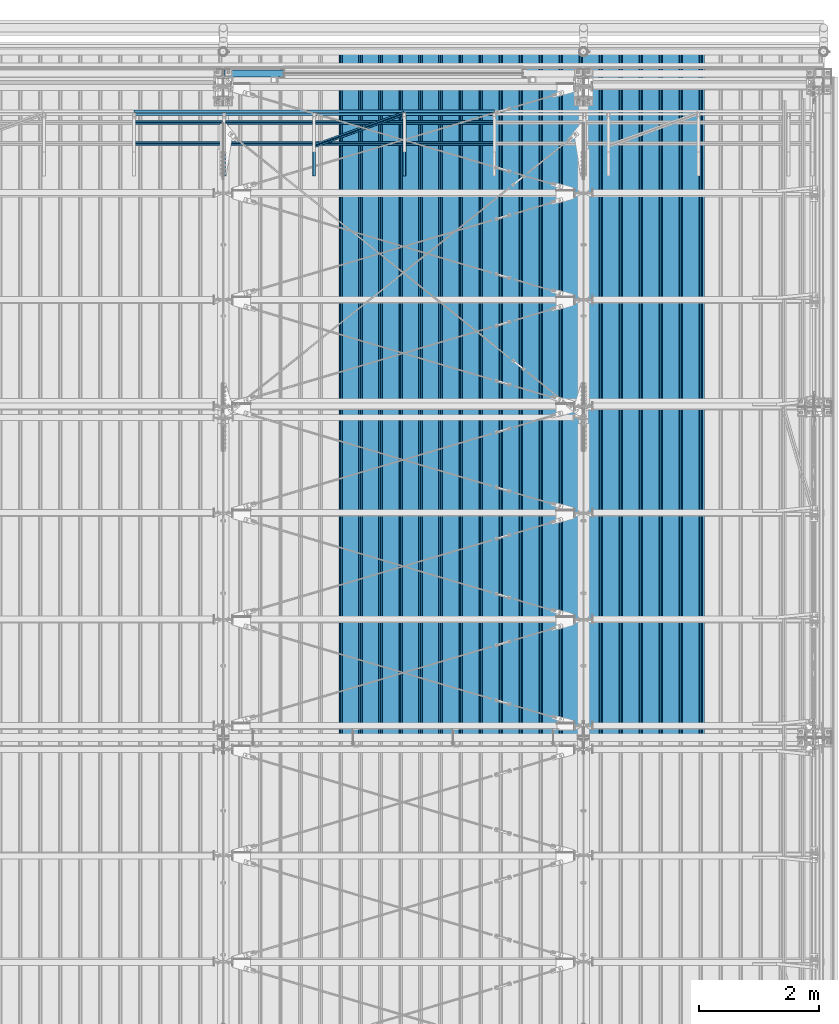
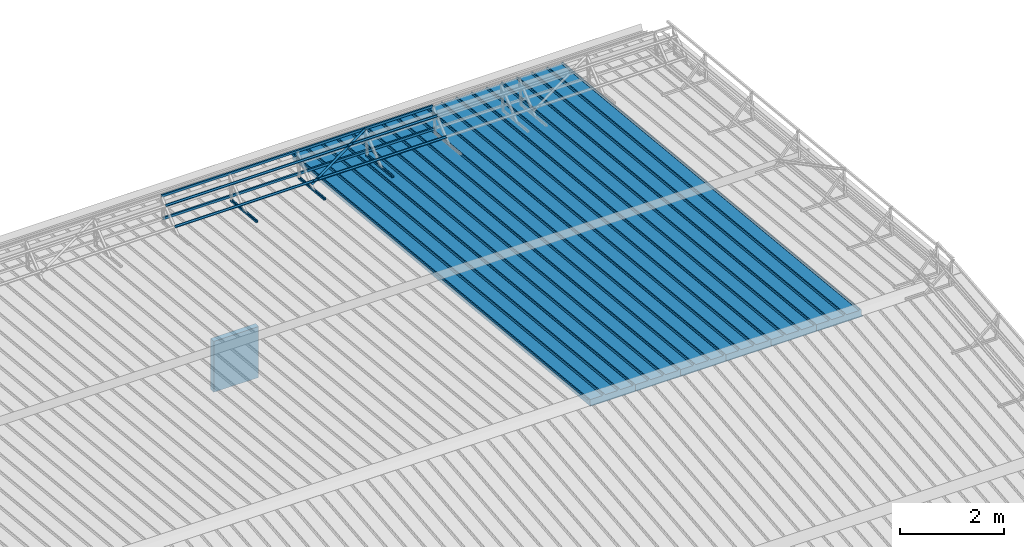
# One storey, part 77 of 709: 15 beams, 15 elements without a shape of their own.
"""IFC4 building model written with IfcOpenShell, lengths in millimetres."""

from ifc_helpers import new_model, si_unit, direction, frame, origin_with_axes, place, context, subcontext, project, spatial, line, indexed_curve, outline, extrude, material, element, aggregate, save


model = new_model("IFC4")

# Units and contexts
model_context = context("Model", 3, precision=0.2, world=origin_with_axes(), true_north=direction((0.0, 1.0)))
body_context = subcontext(model_context, "Body", "Model", "MODEL_VIEW")
ifc_project = project(units=[si_unit("LENGTHUNIT", "METRE", prefix="MILLI"), si_unit("AREAUNIT", "SQUARE_METRE"), si_unit("VOLUMEUNIT", "CUBIC_METRE"), si_unit("MASSUNIT", "GRAM", prefix="KILO"), si_unit("TIMEUNIT", "SECOND"), si_unit("PLANEANGLEUNIT", "RADIAN"), si_unit("SOLIDANGLEUNIT", "STERADIAN"), si_unit("THERMODYNAMICTEMPERATUREUNIT", "DEGREE_CELSIUS"), si_unit("LUMINOUSINTENSITYUNIT", "LUMEN")], contexts=[model_context])

# Site, building, storey
site_placement = place(None, origin_with_axes())
site = spatial("IfcSite", under=ifc_project, at=site_placement, CompositionType="ELEMENT")
building_placement = place(site_placement, origin_with_axes())
building = spatial("IfcBuilding", under=site, at=building_placement, Name="Undefined", CompositionType="ELEMENT")
storey_placement = place(building_placement, origin_with_axes())
storey = spatial("IfcBuildingStorey", under=building, at=storey_placement, Name="Undefined", CompositionType="ELEMENT", Elevation=0.0)

# Assembly, beam
assembly_1_placement = place(storey_placement, frame((47452.44, 11009.10459, 8419.96887), z_axis=(1.0, 0.0, 0.0), x_axis=(0.0, 0.9950371902, -0.099503719)))
assembly_1 = element("IfcElementAssembly", 1, at=assembly_1_placement, inside=storey)
ifc_material_1 = material(Name="Insulation", Category="Insulation")
beam_1_placement = place(assembly_1_placement, origin_with_axes())
beam_1 = element("IfcBeam", 2, at=beam_1_placement, material=ifc_material_1, ObjectType="P-99", context=body_context, shape_type="SolidModel", body=[
    extrude(outline(indexed_curve([(-509.8453, 89.5), (-490.1547, 89.5), (-471.67949, 57.5), (-471.67949, -88.5), (-436.67949, -88.5), (-436.67949, -91.5), (562.55841, -91.5), (562.55841, -89.5), (527.55841, -89.5), (527.55841, 57.5), (510.2379, 88.5), (489.7621, 88.5), (472.44159, 58.5), (196.71923, 58.5), (177.66667, 91.5), (155.66667, 91.5), (136.61411, 58.5), (-136.61411, 58.5), (-155.66667, 91.5), (-177.66667, 91.5), (-196.71923, 58.5), (-469.94744, 58.5), (-489.0, 91.5), (-511.0, 91.5), (-527.16581, 63.5), (-525.43376, 62.5)], segments=[line(1, 2, 3, 4, 5, 6, 7, 8, 9, 10, 11, 12, 13, 14, 15, 16, 17, 18, 19, 20, 21, 22, 23, 24, 25, 26, 1)])), frame((0.0, 0.0, 0.0), z_axis=(-1.0, 0.0, 0.0), x_axis=(0.0, 0.0, 1.0)), (0.0, 0.0, -1.0), 11459.0),
])
aggregate(assembly_1, [beam_1])

assembly_2_placement = place(storey_placement, frame((46452.44, 11009.10459, 8419.96887), z_axis=(1.0, 0.0, 0.0), x_axis=(0.0, 0.9950371902, -0.099503719)))
assembly_2 = element("IfcElementAssembly", 3, at=assembly_2_placement, inside=storey)
beam_2_placement = place(assembly_2_placement, origin_with_axes())
beam_2 = element("IfcBeam", 4, at=beam_2_placement, material=ifc_material_1, ObjectType="P-99", context=body_context, shape_type="SolidModel", body=[
    extrude(outline(indexed_curve([(-509.8453, 89.5), (-490.1547, 89.5), (-471.67949, 57.5), (-471.67949, -88.5), (-436.67949, -88.5), (-436.67949, -91.5), (562.55841, -91.5), (562.55841, -89.5), (527.55841, -89.5), (527.55841, 57.5), (510.2379, 88.5), (489.7621, 88.5), (472.44159, 58.5), (196.71923, 58.5), (177.66667, 91.5), (155.66667, 91.5), (136.61411, 58.5), (-136.61411, 58.5), (-155.66667, 91.5), (-177.66667, 91.5), (-196.71923, 58.5), (-469.94744, 58.5), (-489.0, 91.5), (-511.0, 91.5), (-527.16581, 63.5), (-525.43376, 62.5)], segments=[line(1, 2, 3, 4, 5, 6, 7, 8, 9, 10, 11, 12, 13, 14, 15, 16, 17, 18, 19, 20, 21, 22, 23, 24, 25, 26, 1)])), frame((0.0, 0.0, 0.0), z_axis=(-1.0, 0.0, 0.0), x_axis=(0.0, 0.0, 1.0)), (0.0, 0.0, -1.0), 11459.0),
])
aggregate(assembly_2, [beam_2])

assembly_3_placement = place(storey_placement, frame((45452.44, 11009.10459, 8419.96887), z_axis=(1.0, 0.0, 0.0), x_axis=(0.0, 0.9950371902, -0.099503719)))
assembly_3 = element("IfcElementAssembly", 5, at=assembly_3_placement, inside=storey)
beam_3_placement = place(assembly_3_placement, origin_with_axes())
beam_3 = element("IfcBeam", 6, at=beam_3_placement, material=ifc_material_1, ObjectType="P-99", context=body_context, shape_type="SolidModel", body=[
    extrude(outline(indexed_curve([(-509.8453, 89.5), (-490.1547, 89.5), (-471.67949, 57.5), (-471.67949, -88.5), (-436.67949, -88.5), (-436.67949, -91.5), (562.55841, -91.5), (562.55841, -89.5), (527.55841, -89.5), (527.55841, 57.5), (510.2379, 88.5), (489.7621, 88.5), (472.44159, 58.5), (196.71923, 58.5), (177.66667, 91.5), (155.66667, 91.5), (136.61411, 58.5), (-136.61411, 58.5), (-155.66667, 91.5), (-177.66667, 91.5), (-196.71923, 58.5), (-469.94744, 58.5), (-489.0, 91.5), (-511.0, 91.5), (-527.16581, 63.5), (-525.43376, 62.5)], segments=[line(1, 2, 3, 4, 5, 6, 7, 8, 9, 10, 11, 12, 13, 14, 15, 16, 17, 18, 19, 20, 21, 22, 23, 24, 25, 26, 1)])), frame((0.0, 0.0, 0.0), z_axis=(-1.0, 0.0, 0.0), x_axis=(0.0, 0.0, 1.0)), (0.0, 0.0, -1.0), 11459.0),
])
aggregate(assembly_3, [beam_3])

assembly_4_placement = place(storey_placement, frame((44452.44, 11009.10459, 8419.96887), z_axis=(1.0, 0.0, 0.0), x_axis=(0.0, 0.9950371902, -0.099503719)))
assembly_4 = element("IfcElementAssembly", 7, at=assembly_4_placement, inside=storey)
beam_4_placement = place(assembly_4_placement, origin_with_axes())
beam_4 = element("IfcBeam", 8, at=beam_4_placement, material=ifc_material_1, ObjectType="P-99", context=body_context, shape_type="SolidModel", body=[
    extrude(outline(indexed_curve([(-509.8453, 89.5), (-490.1547, 89.5), (-471.67949, 57.5), (-471.67949, -88.5), (-436.67949, -88.5), (-436.67949, -91.5), (562.55841, -91.5), (562.55841, -89.5), (527.55841, -89.5), (527.55841, 57.5), (510.2379, 88.5), (489.7621, 88.5), (472.44159, 58.5), (196.71923, 58.5), (177.66667, 91.5), (155.66667, 91.5), (136.61411, 58.5), (-136.61411, 58.5), (-155.66667, 91.5), (-177.66667, 91.5), (-196.71923, 58.5), (-469.94744, 58.5), (-489.0, 91.5), (-511.0, 91.5), (-527.16581, 63.5), (-525.43376, 62.5)], segments=[line(1, 2, 3, 4, 5, 6, 7, 8, 9, 10, 11, 12, 13, 14, 15, 16, 17, 18, 19, 20, 21, 22, 23, 24, 25, 26, 1)])), frame((0.0, 0.0, 0.0), z_axis=(-1.0, 0.0, 0.0), x_axis=(0.0, 0.0, 1.0)), (0.0, 0.0, -1.0), 11459.0),
])
aggregate(assembly_4, [beam_4])

assembly_5_placement = place(storey_placement, frame((43452.44, 11009.10459, 8419.96887), z_axis=(1.0, 0.0, 0.0), x_axis=(0.0, 0.9950371902, -0.099503719)))
assembly_5 = element("IfcElementAssembly", 9, at=assembly_5_placement, inside=storey)
beam_5_placement = place(assembly_5_placement, origin_with_axes())
beam_5 = element("IfcBeam", 10, at=beam_5_placement, material=ifc_material_1, ObjectType="P-99", context=body_context, shape_type="SolidModel", body=[
    extrude(outline(indexed_curve([(-509.8453, 89.5), (-490.1547, 89.5), (-471.67949, 57.5), (-471.67949, -88.5), (-436.67949, -88.5), (-436.67949, -91.5), (562.55841, -91.5), (562.55841, -89.5), (527.55841, -89.5), (527.55841, 57.5), (510.2379, 88.5), (489.7621, 88.5), (472.44159, 58.5), (196.71923, 58.5), (177.66667, 91.5), (155.66667, 91.5), (136.61411, 58.5), (-136.61411, 58.5), (-155.66667, 91.5), (-177.66667, 91.5), (-196.71923, 58.5), (-469.94744, 58.5), (-489.0, 91.5), (-511.0, 91.5), (-527.16581, 63.5), (-525.43376, 62.5)], segments=[line(1, 2, 3, 4, 5, 6, 7, 8, 9, 10, 11, 12, 13, 14, 15, 16, 17, 18, 19, 20, 21, 22, 23, 24, 25, 26, 1)])), frame((0.0, 0.0, 0.0), z_axis=(-1.0, 0.0, 0.0), x_axis=(0.0, 0.0, 1.0)), (0.0, 0.0, -1.0), 11459.0),
])
aggregate(assembly_5, [beam_5])

assembly_6_placement = place(storey_placement, frame((42452.44, 11009.10459, 8419.96887), z_axis=(1.0, 0.0, 0.0), x_axis=(0.0, 0.9950371902, -0.099503719)))
assembly_6 = element("IfcElementAssembly", 11, at=assembly_6_placement, inside=storey)
beam_6_placement = place(assembly_6_placement, origin_with_axes())
beam_6 = element("IfcBeam", 12, at=beam_6_placement, material=ifc_material_1, ObjectType="P-99", context=body_context, shape_type="SolidModel", body=[
    extrude(outline(indexed_curve([(-509.8453, 89.5), (-490.1547, 89.5), (-471.67949, 57.5), (-471.67949, -88.5), (-436.67949, -88.5), (-436.67949, -91.5), (562.55841, -91.5), (562.55841, -89.5), (527.55841, -89.5), (527.55841, 57.5), (510.2379, 88.5), (489.7621, 88.5), (472.44159, 58.5), (196.71923, 58.5), (177.66667, 91.5), (155.66667, 91.5), (136.61411, 58.5), (-136.61411, 58.5), (-155.66667, 91.5), (-177.66667, 91.5), (-196.71923, 58.5), (-469.94744, 58.5), (-489.0, 91.5), (-511.0, 91.5), (-527.16581, 63.5), (-525.43376, 62.5)], segments=[line(1, 2, 3, 4, 5, 6, 7, 8, 9, 10, 11, 12, 13, 14, 15, 16, 17, 18, 19, 20, 21, 22, 23, 24, 25, 26, 1)])), frame((0.0, 0.0, 0.0), z_axis=(-1.0, 0.0, 0.0), x_axis=(0.0, 0.0, 1.0)), (0.0, 0.0, -1.0), 11459.0),
])
aggregate(assembly_6, [beam_6])

assembly_7_placement = place(storey_placement, frame((43015.0, 21349.29926, 7565.33969), z_axis=(0.0, 0.099503719, 0.9950371902), x_axis=(0.0, -0.9950371902, 0.099503719)))
assembly_7 = element("IfcElementAssembly", 13, at=assembly_7_placement, inside=storey)
ifc_material_2 = material(Name="Steel_Undefined", Category="STEEL")
beam_7_placement = place(assembly_7_placement, origin_with_axes())
beam_7 = element("IfcBeam", 14, at=beam_7_placement, material=ifc_material_2, ObjectType="601", context=body_context, shape_type="SolidModel", body=[
    extrude(outline(indexed_curve([(-20.0, -25.0), (20.0, -25.0), (20.0, -22.5), (-17.5, -22.5), (-17.5, 22.5), (20.0, 22.5), (20.0, 25.0), (-20.0, 25.0)], segments=[line(1, 2, 3, 4, 5, 6, 7, 8, 1)])), frame((0.0, 0.0, 0.0), z_axis=(-1.0, 0.0, 0.0), x_axis=(0.0, 0.0, 1.0)), (0.0, 0.0, -1.0), 1000.0),
])
aggregate(assembly_7, [beam_7])

assembly_8_placement = place(storey_placement, frame((41515.0, 21349.29926, 7565.33969), z_axis=(0.0, 0.099503719, 0.9950371902), x_axis=(0.0, -0.9950371902, 0.099503719)))
assembly_8 = element("IfcElementAssembly", 15, at=assembly_8_placement, inside=storey)
beam_8_placement = place(assembly_8_placement, origin_with_axes())
beam_8 = element("IfcBeam", 16, at=beam_8_placement, material=ifc_material_2, ObjectType="601", context=body_context, shape_type="SolidModel", body=[
    extrude(outline(indexed_curve([(-20.0, -25.0), (20.0, -25.0), (20.0, -22.5), (-17.5, -22.5), (-17.5, 22.5), (20.0, 22.5), (20.0, 25.0), (-20.0, 25.0)], segments=[line(1, 2, 3, 4, 5, 6, 7, 8, 1)])), frame((0.0, 0.0, 0.0), z_axis=(-1.0, 0.0, 0.0), x_axis=(0.0, 0.0, 1.0)), (0.0, 0.0, -1.0), 1000.0),
])
aggregate(assembly_8, [beam_8])

assembly_9_placement = place(storey_placement, frame((40015.0, 21349.29926, 7565.33969), z_axis=(0.0, 0.099503719, 0.9950371902), x_axis=(0.0, -0.9950371902, 0.099503719)))
assembly_9 = element("IfcElementAssembly", 17, at=assembly_9_placement, inside=storey)
beam_9_placement = place(assembly_9_placement, origin_with_axes())
beam_9 = element("IfcBeam", 18, at=beam_9_placement, material=ifc_material_2, ObjectType="601", context=body_context, shape_type="SolidModel", body=[
    extrude(outline(indexed_curve([(-20.0, -25.0), (20.0, -25.0), (20.0, -22.5), (-17.5, -22.5), (-17.5, 22.5), (20.0, 22.5), (20.0, 25.0), (-20.0, 25.0)], segments=[line(1, 2, 3, 4, 5, 6, 7, 8, 1)])), frame((0.0, 0.0, 0.0), z_axis=(-1.0, 0.0, 0.0), x_axis=(0.0, 0.0, 1.0)), (0.0, 0.0, -1.0), 1000.0),
])
aggregate(assembly_9, [beam_9])

assembly_10_placement = place(storey_placement, frame((44515.0, 21426.91216, 8140.47118), z_axis=(0.0, 0.9950371902, -0.099503719), x_axis=(-1.0, 0.0, 0.0)))
assembly_10 = element("IfcElementAssembly", 19, at=assembly_10_placement, inside=storey)
beam_10_placement = place(assembly_10_placement, origin_with_axes())
beam_10 = element("IfcBeam", 20, at=beam_10_placement, material=ifc_material_2, ObjectType="606", context=body_context, shape_type="SolidModel", body=[
    extrude(outline(indexed_curve([(-20.0, -25.0), (20.0, -25.0), (20.0, -22.5), (-17.5, -22.5), (-17.5, 22.5), (20.0, 22.5), (20.0, 25.0), (-20.0, 25.0)], segments=[line(1, 2, 3, 4, 5, 6, 7, 8, 1)])), frame((0.0, 0.0, 0.0), z_axis=(-1.0, 0.0, 0.0), x_axis=(0.0, 0.0, 1.0)), (0.0, 0.0, -1.0), 6000.0),
])
aggregate(assembly_10, [beam_10])

assembly_11_placement = place(storey_placement, frame((44515.0, 21377.1603, 7642.95259), z_axis=(0.0, 0.9950371902, -0.099503719), x_axis=(-1.0, 0.0, 0.0)))
assembly_11 = element("IfcElementAssembly", 21, at=assembly_11_placement, inside=storey)
beam_11_placement = place(assembly_11_placement, origin_with_axes())
beam_11 = element("IfcBeam", 22, at=beam_11_placement, material=ifc_material_2, ObjectType="606", context=body_context, shape_type="SolidModel", body=[
    extrude(outline(indexed_curve([(-20.0, -25.0), (20.0, -25.0), (20.0, -22.5), (-17.5, -22.5), (-17.5, 22.5), (20.0, 22.5), (20.0, 25.0), (-20.0, 25.0)], segments=[line(1, 2, 3, 4, 5, 6, 7, 8, 1)])), frame((0.0, 0.0, 0.0), z_axis=(-1.0, 0.0, 0.0), x_axis=(0.0, 0.0, 1.0)), (0.0, 0.0, -1.0), 6000.0),
])
aggregate(assembly_11, [beam_11])

assembly_12_placement = place(storey_placement, frame((44515.0, 21239.5552, 8031.29285), z_axis=(0.0, -0.6332377902, 0.7739572992), x_axis=(-1.0, 0.0, 0.0)))
assembly_12 = element("IfcElementAssembly", 23, at=assembly_12_placement, inside=storey)
beam_12_placement = place(assembly_12_placement, origin_with_axes())
beam_12 = element("IfcBeam", 24, at=beam_12_placement, material=ifc_material_2, ObjectType="606", context=body_context, shape_type="SolidModel", body=[
    extrude(outline(indexed_curve([(-20.0, -25.0), (20.0, -25.0), (20.0, -22.5), (-17.5, -22.5), (-17.5, 22.5), (20.0, 22.5), (20.0, 25.0), (-20.0, 25.0)], segments=[line(1, 2, 3, 4, 5, 6, 7, 8, 1)])), frame((0.0, 0.0, 0.0), z_axis=(-1.0, 0.0, 0.0), x_axis=(0.0, 0.0, 1.0)), (0.0, 0.0, -1.0), 6000.0),
])
aggregate(assembly_12, [beam_12])

assembly_13_placement = place(storey_placement, frame((44515.0, 20892.41357, 7747.26788), z_axis=(0.0, -0.6332377902, 0.7739572992), x_axis=(-1.0, 0.0, 0.0)))
assembly_13 = element("IfcElementAssembly", 25, at=assembly_13_placement, inside=storey)
beam_13_placement = place(assembly_13_placement, origin_with_axes())
beam_13 = element("IfcBeam", 26, at=beam_13_placement, material=ifc_material_2, ObjectType="606", context=body_context, shape_type="SolidModel", body=[
    extrude(outline(indexed_curve([(-20.0, -25.0), (20.0, -25.0), (20.0, -22.5), (-17.5, -22.5), (-17.5, 22.5), (20.0, 22.5), (20.0, 25.0), (-20.0, 25.0)], segments=[line(1, 2, 3, 4, 5, 6, 7, 8, 1)])), frame((0.0, 0.0, 0.0), z_axis=(-1.0, 0.0, 0.0), x_axis=(0.0, 0.0, 1.0)), (0.0, 0.0, -1.0), 6000.0),
])
aggregate(assembly_13, [beam_13])

assembly_14_placement = place(storey_placement, frame((43015.0, 21394.34666, 8157.9404), z_axis=(0.0, -0.6332377902, 0.7739572992), x_axis=(-0.9061831398, -0.3272952929, -0.2677870579)))
assembly_14 = element("IfcElementAssembly", 27, at=assembly_14_placement, inside=storey)
beam_14_placement = place(assembly_14_placement, origin_with_axes())
beam_14 = element("IfcBeam", 28, at=beam_14_placement, material=ifc_material_2, ObjectType="605", context=body_context, shape_type="SolidModel", body=[
    extrude(outline(indexed_curve([(-20.0, -25.0), (20.0, -25.0), (20.0, -22.5), (-17.5, -22.5), (-17.5, 22.5), (20.0, 22.5), (20.0, 25.0), (-20.0, 25.0)], segments=[line(1, 2, 3, 4, 5, 6, 7, 8, 1)])), frame((0.0, 0.0, 0.0), z_axis=(-1.0, 0.0, 0.0), x_axis=(0.0, 0.0, 1.0)), (0.0, 0.0, -1.0), 1655.29454),
])
aggregate(assembly_14, [beam_14])

assembly_15_placement = place(storey_placement, frame((40010.0, 22060.0, 3275.0), z_axis=(0.0, 0.0, -1.0), x_axis=(1.0, 0.0, 0.0)))
assembly_15 = element("IfcElementAssembly", 29, at=assembly_15_placement, inside=storey)
beam_15_placement = place(assembly_15_placement, origin_with_axes())
beam_15 = element("IfcBeam", 30, at=beam_15_placement, material=ifc_material_1, ObjectType="P-110", context=body_context, shape_type="SolidModel", body=[
    extrude(outline(indexed_curve([(-595.0, -60.0), (595.0, -60.0), (595.0, 60.0), (-595.0, 60.0)], segments=[line(1, 2, 3, 4, 1)])), frame((0.0, 0.0, 0.0), z_axis=(-1.0, 0.0, 0.0), x_axis=(0.0, 0.0, 1.0)), (0.0, 0.0, -1.0), 990.0),
])
aggregate(assembly_15, [beam_15])

save(model, "model.ifc")
